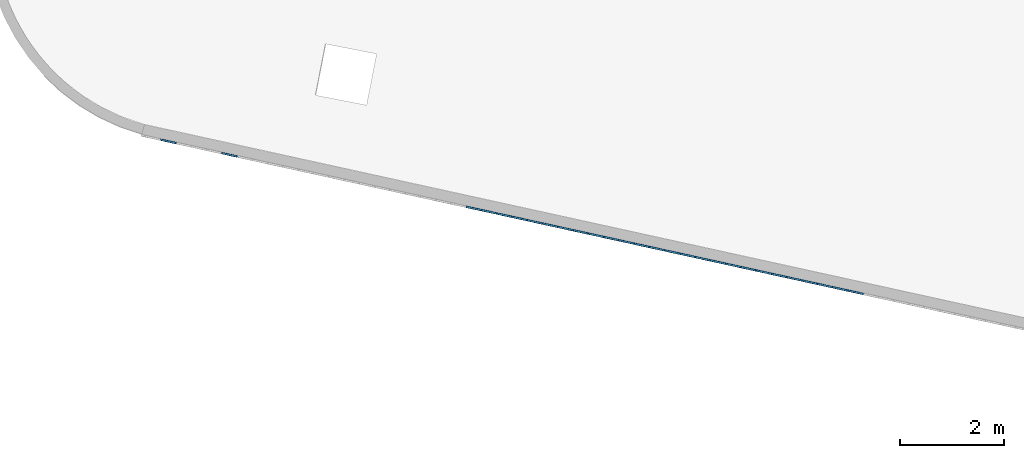
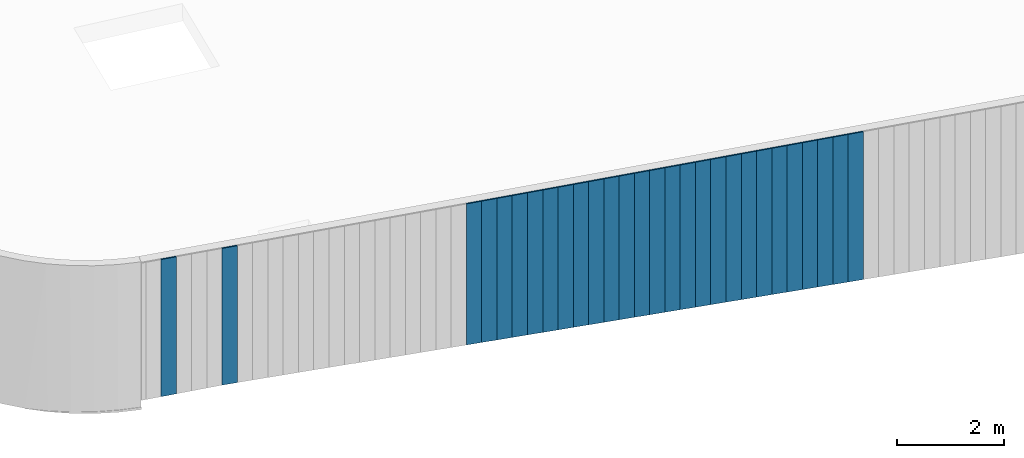
# One storey, part 1 of 18: 28 plates, 1 element without a shape of its own.
"""IFC2X3 building model written with IfcOpenShell, lengths in centimetres."""

from ifc_helpers import new_model, entity, si_unit, converted_unit, derived_unit, direction, frame, origin, place, context, subcontext, project, spatial, polyline, outline, extrude, source, transform, mapped, material, layer, layer_set, layer_usage, type_object, type_shapes, element, aggregate, save


model = new_model("IFC2X3")

# Units and contexts
model_context = context("Model", 3, precision=0.001, world=origin(), true_north=direction((6.12303176911189e-17, 1.0)))
body_context = subcontext(model_context, "Body", "Model", "MODEL_VIEW")
ifc_project = project(units=[si_unit("LENGTHUNIT", "METRE", prefix="CENTI"), si_unit("AREAUNIT", "SQUARE_METRE"), si_unit("VOLUMEUNIT", "CUBIC_METRE"), converted_unit("PLANEANGLEUNIT", "DEGREE", entity("IfcRatioMeasure", 0.0174532925199433), si_unit("PLANEANGLEUNIT", "RADIAN"), dimensions=[0, 0, 0, 0, 0, 0, 0]), si_unit("MASSUNIT", "GRAM", prefix="KILO"), derived_unit("MASSDENSITYUNIT", [(si_unit("MASSUNIT", "GRAM", prefix="KILO"), 1), (si_unit("LENGTHUNIT", "METRE"), -3)]), si_unit("TIMEUNIT", "SECOND"), si_unit("FREQUENCYUNIT", "HERTZ"), si_unit("THERMODYNAMICTEMPERATUREUNIT", "DEGREE_CELSIUS"), derived_unit("THERMALTRANSMITTANCEUNIT", [(si_unit("MASSUNIT", "GRAM", prefix="KILO"), 1), (si_unit("THERMODYNAMICTEMPERATUREUNIT", "KELVIN"), -1), (si_unit("TIMEUNIT", "SECOND"), -3)]), derived_unit("VOLUMETRICFLOWRATEUNIT", [(si_unit("LENGTHUNIT", "METRE"), 3), (si_unit("TIMEUNIT", "SECOND"), -1)]), si_unit("ELECTRICCURRENTUNIT", "AMPERE"), si_unit("ELECTRICVOLTAGEUNIT", "VOLT"), si_unit("POWERUNIT", "WATT"), si_unit("FORCEUNIT", "NEWTON", prefix="KILO"), si_unit("ILLUMINANCEUNIT", "LUX"), si_unit("LUMINOUSFLUXUNIT", "LUMEN"), si_unit("LUMINOUSINTENSITYUNIT", "CANDELA"), derived_unit("USERDEFINED", [(si_unit("MASSUNIT", "GRAM", prefix="KILO"), -1), (si_unit("LENGTHUNIT", "METRE"), -2), (si_unit("TIMEUNIT", "SECOND"), 3), (si_unit("LUMINOUSFLUXUNIT", "LUMEN"), 1)]), derived_unit("LINEARVELOCITYUNIT", [(si_unit("LENGTHUNIT", "METRE"), 1), (si_unit("TIMEUNIT", "SECOND"), -1)]), si_unit("PRESSUREUNIT", "PASCAL"), derived_unit("USERDEFINED", [(si_unit("LENGTHUNIT", "METRE"), -2), (si_unit("MASSUNIT", "GRAM", prefix="KILO"), 1), (si_unit("TIMEUNIT", "SECOND"), -2)])], contexts=[model_context])

# Site, building, storey
site_placement = place(None, origin())
site = spatial("IfcSite", under=ifc_project, at=site_placement, CompositionType="ELEMENT")
building_placement = place(site_placement, origin())
building = spatial("IfcBuilding", under=site, at=building_placement, CompositionType="ELEMENT")
storey_placement = place(building_placement, frame((0.0, 0.0, 1422.0)))
storey = spatial("IfcBuildingStorey", under=building, at=storey_placement, CompositionType="ELEMENT", Elevation=1422.0)

# Curtain wall, plates
curtain_wall_type = type_object("IfcCurtainWallType", PredefinedType="NOTDEFINED")
curtain_wall_placement = place(storey_placement, frame((0.0, 0.0, -1422.0)))
curtain_wall = element("IfcCurtainWall", 1, at=curtain_wall_placement, inside=storey, type_object=curtain_wall_type)
ifc_material = material()
ifc_layer = layer(ifc_material, 3.0)
ifc_layer_set = layer_set([ifc_layer])
ifc_layer_usage_1 = layer_usage(ifc_layer_set, "AXIS3", "POSITIVE", 0.0492125984251968)
plate_type_1 = type_object("IfcPlateType", Name="Panneau plein ST", PredefinedType="CURTAIN_PANEL", material=ifc_layer_set)
shared_shape_1 = source(origin(), body_context, "Body", "SweptSolid", [
    extrude(outline(polyline([(-169.132854368732, -15.0), (168.833289240814, -15.0), (168.833289240814, 15.0), (-168.533724112897, 15.0), (-169.132854368732, -15.0)])), frame((0.0, 0.0, 169.132854368732), z_axis=(0.0, 1.0, 0.0), x_axis=(0.0, 0.0, 1.0)), (0.0, 0.0, 1.0), 3.0),
])
type_shapes(plate_type_1, [shared_shape_1])
plate_1_placement = place(curtain_wall_placement, frame((5430.19102317724, 780.217240085459, 1084.03385639045), z_axis=(0.0, 0.0, 1.0), x_axis=(-0.976731958442773, 0.214463706385357, 0.0)))
plate_1 = element("IfcPlate", 2, at=plate_1_placement, type_object=plate_type_1, material=ifc_layer_usage_1, ObjectType="Panneau plein ST", context=body_context, shape_type="MappedRepresentation", body=[
    mapped(shared_shape_1, transform((0.0, 0.0, 0.0), scale=1.0)),
])
ifc_layer_usage_2 = layer_usage(ifc_layer_set, "AXIS3", "POSITIVE", 0.0492125984251968)
plate_type_2 = type_object("IfcPlateType", Name="Panneau plein ST", PredefinedType="CURTAIN_PANEL", material=ifc_layer_set)
shared_shape_2 = source(origin(), body_context, "Body", "SweptSolid", [
    extrude(outline(polyline([(-168.833289240814, -15.0), (168.533724112896, -15.0), (168.533724112896, 15.0), (-168.234158984978, 15.0), (-168.833289240814, -15.0)])), frame((0.0, 0.0, 168.833289240814), z_axis=(0.0, 1.0, 0.0), x_axis=(0.0, 0.0, 1.0)), (0.0, 0.0, 1.0), 3.0),
])
type_shapes(plate_type_2, [shared_shape_2])
plate_2_placement = place(curtain_wall_placement, frame((5400.88906442396, 786.65115127702, 1084.63298664629), z_axis=(0.0, 0.0, 1.0), x_axis=(-0.976731958442773, 0.214463706385357, 0.0)))
plate_2 = element("IfcPlate", 3, at=plate_2_placement, type_object=plate_type_2, material=ifc_layer_usage_2, ObjectType="Panneau plein ST", context=body_context, shape_type="MappedRepresentation", body=[
    mapped(shared_shape_2, transform((0.0, 0.0, 0.0), scale=1.0)),
])
ifc_layer_usage_3 = layer_usage(ifc_layer_set, "AXIS3", "POSITIVE", 0.0492125984251968)
plate_type_3 = type_object("IfcPlateType", Name="Panneau plein ST", PredefinedType="CURTAIN_PANEL", material=ifc_layer_set)
shared_shape_3 = source(origin(), body_context, "Body", "SweptSolid", [
    extrude(outline(polyline([(-168.533724112896, -15.0), (168.234158984978, -15.0), (168.234158984978, 15.0), (-167.93459385706, 15.0), (-168.533724112896, -15.0)])), frame((0.0, 0.0, 168.533724112896), z_axis=(0.0, 1.0, 0.0), x_axis=(0.0, 0.0, 1.0)), (0.0, 0.0, 1.0), 3.0),
])
type_shapes(plate_type_3, [shared_shape_3])
plate_3_placement = place(curtain_wall_placement, frame((5371.58710567067, 793.085062468581, 1085.23211690213), z_axis=(0.0, 0.0, 1.0), x_axis=(-0.976731958442773, 0.214463706385357, 0.0)))
plate_3 = element("IfcPlate", 4, at=plate_3_placement, type_object=plate_type_3, material=ifc_layer_usage_3, ObjectType="Panneau plein ST", context=body_context, shape_type="MappedRepresentation", body=[
    mapped(shared_shape_3, transform((0.0, 0.0, 0.0), scale=1.0)),
])
ifc_layer_usage_4 = layer_usage(ifc_layer_set, "AXIS3", "POSITIVE", 0.0492125984251968)
plate_type_4 = type_object("IfcPlateType", Name="Panneau plein ST", PredefinedType="CURTAIN_PANEL", material=ifc_layer_set)
shared_shape_4 = source(origin(), body_context, "Body", "SweptSolid", [
    extrude(outline(polyline([(-168.234158984978, -15.0), (167.93459385706, -15.0), (167.93459385706, 15.0), (-167.635028729142, 15.0), (-168.234158984978, -15.0)])), frame((0.0, 0.0, 168.234158984978), z_axis=(0.0, 1.0, 0.0), x_axis=(0.0, 0.0, 1.0)), (0.0, 0.0, 1.0), 3.0),
])
type_shapes(plate_type_4, [shared_shape_4])
plate_4_placement = place(curtain_wall_placement, frame((5342.28514691739, 799.518973660141, 1085.83124715796), z_axis=(0.0, 0.0, 1.0), x_axis=(-0.976731958442773, 0.214463706385357, 0.0)))
plate_4 = element("IfcPlate", 5, at=plate_4_placement, type_object=plate_type_4, material=ifc_layer_usage_4, ObjectType="Panneau plein ST", context=body_context, shape_type="MappedRepresentation", body=[
    mapped(shared_shape_4, transform((0.0, 0.0, 0.0), scale=1.0)),
])
ifc_layer_usage_5 = layer_usage(ifc_layer_set, "AXIS3", "POSITIVE", 0.0492125984251968)
plate_type_5 = type_object("IfcPlateType", Name="Panneau plein ST", PredefinedType="CURTAIN_PANEL", material=ifc_layer_set)
shared_shape_5 = source(origin(), body_context, "Body", "SweptSolid", [
    extrude(outline(polyline([(-167.93459385706, -15.0), (167.635028729142, -15.0), (167.635028729142, 15.0), (-167.335463601224, 15.0), (-167.93459385706, -15.0)])), frame((0.0, 0.0, 167.93459385706), z_axis=(0.0, 1.0, 0.0), x_axis=(0.0, 0.0, 1.0)), (0.0, 0.0, 1.0), 3.0),
])
type_shapes(plate_type_5, [shared_shape_5])
plate_5_placement = place(curtain_wall_placement, frame((5312.98318816411, 805.952884851702, 1086.4303774138), z_axis=(0.0, 0.0, 1.0), x_axis=(-0.976731958442773, 0.214463706385357, 0.0)))
plate_5 = element("IfcPlate", 6, at=plate_5_placement, type_object=plate_type_5, material=ifc_layer_usage_5, ObjectType="Panneau plein ST", context=body_context, shape_type="MappedRepresentation", body=[
    mapped(shared_shape_5, transform((0.0, 0.0, 0.0), scale=1.0)),
])
ifc_layer_usage_6 = layer_usage(ifc_layer_set, "AXIS3", "POSITIVE", 0.0492125984251968)
plate_type_6 = type_object("IfcPlateType", Name="Panneau plein ST", PredefinedType="CURTAIN_PANEL", material=ifc_layer_set)
shared_shape_6 = source(origin(), body_context, "Body", "SweptSolid", [
    extrude(outline(polyline([(-167.635028729142, -15.0), (167.335463601224, -15.0), (167.335463601224, 15.0), (-167.035898473306, 15.0), (-167.635028729142, -15.0)])), frame((0.0, 0.0, 167.635028729142), z_axis=(0.0, 1.0, 0.0), x_axis=(0.0, 0.0, 1.0)), (0.0, 0.0, 1.0), 3.0),
])
type_shapes(plate_type_6, [shared_shape_6])
plate_6_placement = place(curtain_wall_placement, frame((5283.68122941082, 812.386796043263, 1087.02950766963), z_axis=(0.0, 0.0, 1.0), x_axis=(-0.976731958442773, 0.214463706385357, 0.0)))
plate_6 = element("IfcPlate", 7, at=plate_6_placement, type_object=plate_type_6, material=ifc_layer_usage_6, ObjectType="Panneau plein ST", context=body_context, shape_type="MappedRepresentation", body=[
    mapped(shared_shape_6, transform((0.0, 0.0, 0.0), scale=1.0)),
])
ifc_layer_usage_7 = layer_usage(ifc_layer_set, "AXIS3", "POSITIVE", 0.0492125984251968)
plate_type_7 = type_object("IfcPlateType", Name="Panneau plein ST", PredefinedType="CURTAIN_PANEL", material=ifc_layer_set)
shared_shape_7 = source(origin(), body_context, "Body", "SweptSolid", [
    extrude(outline(polyline([(-167.335463601224, -15.0), (167.035898473306, -15.0), (167.035898473306, 15.0), (-166.736333345388, 15.0), (-167.335463601224, -15.0)])), frame((0.0, 0.0, 167.335463601224), z_axis=(0.0, 1.0, 0.0), x_axis=(0.0, 0.0, 1.0)), (0.0, 0.0, 1.0), 3.0),
])
type_shapes(plate_type_7, [shared_shape_7])
plate_7_placement = place(curtain_wall_placement, frame((5254.37927065754, 818.820707234823, 1087.62863792547), z_axis=(0.0, 0.0, 1.0), x_axis=(-0.976731958442773, 0.214463706385357, 0.0)))
plate_7 = element("IfcPlate", 8, at=plate_7_placement, type_object=plate_type_7, material=ifc_layer_usage_7, ObjectType="Panneau plein ST", context=body_context, shape_type="MappedRepresentation", body=[
    mapped(shared_shape_7, transform((0.0, 0.0, 0.0), scale=1.0)),
])
ifc_layer_usage_8 = layer_usage(ifc_layer_set, "AXIS3", "POSITIVE", 0.0492125984251968)
plate_type_8 = type_object("IfcPlateType", Name="Panneau plein ST", PredefinedType="CURTAIN_PANEL", material=ifc_layer_set)
shared_shape_8 = source(origin(), body_context, "Body", "SweptSolid", [
    extrude(outline(polyline([(-167.035898473306, -15.0), (166.736333345388, -15.0), (166.736333345388, 15.0), (-166.43676821747, 15.0), (-167.035898473306, -15.0)])), frame((0.0, 0.0, 167.035898473306), z_axis=(0.0, 1.0, 0.0), x_axis=(0.0, 0.0, 1.0)), (0.0, 0.0, 1.0), 3.0),
])
type_shapes(plate_type_8, [shared_shape_8])
plate_8_placement = place(curtain_wall_placement, frame((5225.07731190426, 825.254618426384, 1088.22776818131), z_axis=(0.0, 0.0, 1.0), x_axis=(-0.976731958442773, 0.214463706385357, 0.0)))
plate_8 = element("IfcPlate", 9, at=plate_8_placement, type_object=plate_type_8, material=ifc_layer_usage_8, ObjectType="Panneau plein ST", context=body_context, shape_type="MappedRepresentation", body=[
    mapped(shared_shape_8, transform((0.0, 0.0, 0.0), scale=1.0)),
])
ifc_layer_usage_9 = layer_usage(ifc_layer_set, "AXIS3", "POSITIVE", 0.0492125984251968)
plate_type_9 = type_object("IfcPlateType", Name="Panneau plein ST", PredefinedType="CURTAIN_PANEL", material=ifc_layer_set)
shared_shape_9 = source(origin(), body_context, "Body", "SweptSolid", [
    extrude(outline(polyline([(-166.736333345388, -15.0), (166.43676821747, -15.0), (166.43676821747, 15.0), (-166.137203089552, 15.0), (-166.736333345388, -15.0)])), frame((0.0, 0.0, 166.736333345388), z_axis=(0.0, 1.0, 0.0), x_axis=(0.0, 0.0, 1.0)), (0.0, 0.0, 1.0), 3.0),
])
type_shapes(plate_type_9, [shared_shape_9])
plate_9_placement = place(curtain_wall_placement, frame((5195.77535315098, 831.688529617945, 1088.82689843714), z_axis=(0.0, 0.0, 1.0), x_axis=(-0.976731958442773, 0.214463706385357, 0.0)))
plate_9 = element("IfcPlate", 10, at=plate_9_placement, type_object=plate_type_9, material=ifc_layer_usage_9, ObjectType="Panneau plein ST", context=body_context, shape_type="MappedRepresentation", body=[
    mapped(shared_shape_9, transform((0.0, 0.0, 0.0), scale=1.0)),
])
ifc_layer_usage_10 = layer_usage(ifc_layer_set, "AXIS3", "POSITIVE", 0.0492125984251968)
plate_type_10 = type_object("IfcPlateType", Name="Panneau plein ST", PredefinedType="CURTAIN_PANEL", material=ifc_layer_set)
shared_shape_10 = source(origin(), body_context, "Body", "SweptSolid", [
    extrude(outline(polyline([(-166.43676821747, -15.0), (166.137203089552, -15.0), (166.137203089552, 15.0), (-165.837637961634, 15.0), (-166.43676821747, -15.0)])), frame((0.0, 0.0, 166.43676821747), z_axis=(0.0, 1.0, 0.0), x_axis=(0.0, 0.0, 1.0)), (0.0, 0.0, 1.0), 3.0),
])
type_shapes(plate_type_10, [shared_shape_10])
plate_10_placement = place(curtain_wall_placement, frame((5166.47339439769, 838.122440809506, 1089.42602869298), z_axis=(0.0, 0.0, 1.0), x_axis=(-0.976731958442773, 0.214463706385357, 0.0)))
plate_10 = element("IfcPlate", 11, at=plate_10_placement, type_object=plate_type_10, material=ifc_layer_usage_10, ObjectType="Panneau plein ST", context=body_context, shape_type="MappedRepresentation", body=[
    mapped(shared_shape_10, transform((0.0, 0.0, 0.0), scale=1.0)),
])
ifc_layer_usage_11 = layer_usage(ifc_layer_set, "AXIS3", "POSITIVE", 0.0492125984251968)
plate_type_11 = type_object("IfcPlateType", Name="Panneau plein ST", PredefinedType="CURTAIN_PANEL", material=ifc_layer_set)
shared_shape_11 = source(origin(), body_context, "Body", "SweptSolid", [
    extrude(outline(polyline([(-166.137203089552, -15.0), (165.837637961634, -15.0), (165.837637961634, 15.0), (-165.538072833716, 15.0), (-166.137203089552, -15.0)])), frame((0.0, 0.0, 166.137203089552), z_axis=(0.0, 1.0, 0.0), x_axis=(0.0, 0.0, 1.0)), (0.0, 0.0, 1.0), 3.0),
])
type_shapes(plate_type_11, [shared_shape_11])
plate_11_placement = place(curtain_wall_placement, frame((5137.17143564441, 844.556352001067, 1090.02515894881), z_axis=(0.0, 0.0, 1.0), x_axis=(-0.976731958442773, 0.214463706385357, 0.0)))
plate_11 = element("IfcPlate", 12, at=plate_11_placement, type_object=plate_type_11, material=ifc_layer_usage_11, ObjectType="Panneau plein ST", context=body_context, shape_type="MappedRepresentation", body=[
    mapped(shared_shape_11, transform((0.0, 0.0, 0.0), scale=1.0)),
])
ifc_layer_usage_12 = layer_usage(ifc_layer_set, "AXIS3", "POSITIVE", 0.0492125984251968)
plate_type_12 = type_object("IfcPlateType", Name="Panneau plein ST", PredefinedType="CURTAIN_PANEL", material=ifc_layer_set)
shared_shape_12 = source(origin(), body_context, "Body", "SweptSolid", [
    extrude(outline(polyline([(-165.837637961634, -15.0), (165.538072833716, -15.0), (165.538072833716, 15.0), (-165.238507705798, 15.0), (-165.837637961634, -15.0)])), frame((0.0, 0.0, 165.837637961634), z_axis=(0.0, 1.0, 0.0), x_axis=(0.0, 0.0, 1.0)), (0.0, 0.0, 1.0), 3.0),
])
type_shapes(plate_type_12, [shared_shape_12])
plate_12_placement = place(curtain_wall_placement, frame((5107.86947689113, 850.990263192627, 1090.62428920465), z_axis=(0.0, 0.0, 1.0), x_axis=(-0.976731958442773, 0.214463706385357, 0.0)))
plate_12 = element("IfcPlate", 13, at=plate_12_placement, type_object=plate_type_12, material=ifc_layer_usage_12, ObjectType="Panneau plein ST", context=body_context, shape_type="MappedRepresentation", body=[
    mapped(shared_shape_12, transform((0.0, 0.0, 0.0), scale=1.0)),
])
ifc_layer_usage_13 = layer_usage(ifc_layer_set, "AXIS3", "POSITIVE", 0.0492125984251968)
plate_type_13 = type_object("IfcPlateType", Name="Panneau plein ST", PredefinedType="CURTAIN_PANEL", material=ifc_layer_set)
shared_shape_13 = source(origin(), body_context, "Body", "SweptSolid", [
    extrude(outline(polyline([(-165.538072833716, -15.0), (165.238507705798, -15.0), (165.238507705798, 15.0), (-164.93894257788, 15.0), (-165.538072833716, -15.0)])), frame((0.0, 0.0, 165.538072833716), z_axis=(0.0, 1.0, 0.0), x_axis=(0.0, 0.0, 1.0)), (0.0, 0.0, 1.0), 3.0),
])
type_shapes(plate_type_13, [shared_shape_13])
plate_13_placement = place(curtain_wall_placement, frame((5078.56751813784, 857.424174384188, 1091.22341946049), z_axis=(0.0, 0.0, 1.0), x_axis=(-0.976731958442773, 0.214463706385357, 0.0)))
plate_13 = element("IfcPlate", 14, at=plate_13_placement, type_object=plate_type_13, material=ifc_layer_usage_13, ObjectType="Panneau plein ST", context=body_context, shape_type="MappedRepresentation", body=[
    mapped(shared_shape_13, transform((0.0, 0.0, 0.0), scale=1.0)),
])
ifc_layer_usage_14 = layer_usage(ifc_layer_set, "AXIS3", "POSITIVE", 0.0492125984251968)
plate_type_14 = type_object("IfcPlateType", Name="Panneau plein ST", PredefinedType="CURTAIN_PANEL", material=ifc_layer_set)
shared_shape_14 = source(origin(), body_context, "Body", "SweptSolid", [
    extrude(outline(polyline([(-165.238507705798, -15.0), (164.93894257788, -15.0), (164.93894257788, 15.0), (-164.639377449962, 15.0), (-165.238507705798, -15.0)])), frame((0.0, 0.0, 165.238507705798), z_axis=(0.0, 1.0, 0.0), x_axis=(0.0, 0.0, 1.0)), (0.0, 0.0, 1.0), 3.0),
])
type_shapes(plate_type_14, [shared_shape_14])
plate_14_placement = place(curtain_wall_placement, frame((5049.26555938456, 863.858085575749, 1091.82254971632), z_axis=(0.0, 0.0, 1.0), x_axis=(-0.976731958442773, 0.214463706385357, 0.0)))
plate_14 = element("IfcPlate", 15, at=plate_14_placement, type_object=plate_type_14, material=ifc_layer_usage_14, ObjectType="Panneau plein ST", context=body_context, shape_type="MappedRepresentation", body=[
    mapped(shared_shape_14, transform((0.0, 0.0, 0.0), scale=1.0)),
])
ifc_layer_usage_15 = layer_usage(ifc_layer_set, "AXIS3", "POSITIVE", 0.0492125984251968)
plate_type_15 = type_object("IfcPlateType", Name="Panneau plein ST", PredefinedType="CURTAIN_PANEL", material=ifc_layer_set)
shared_shape_15 = source(origin(), body_context, "Body", "SweptSolid", [
    extrude(outline(polyline([(-164.93894257788, -15.0), (164.639377449962, -15.0), (164.639377449962, 15.0), (-164.339812322044, 15.0), (-164.93894257788, -15.0)])), frame((0.0, 0.0, 164.93894257788), z_axis=(0.0, 1.0, 0.0), x_axis=(0.0, 0.0, 1.0)), (0.0, 0.0, 1.0), 3.0),
])
type_shapes(plate_type_15, [shared_shape_15])
plate_15_placement = place(curtain_wall_placement, frame((5019.96360063128, 870.29199676731, 1092.42167997216), z_axis=(0.0, 0.0, 1.0), x_axis=(-0.976731958442773, 0.214463706385357, 0.0)))
plate_15 = element("IfcPlate", 16, at=plate_15_placement, type_object=plate_type_15, material=ifc_layer_usage_15, ObjectType="Panneau plein ST", context=body_context, shape_type="MappedRepresentation", body=[
    mapped(shared_shape_15, transform((0.0, 0.0, 0.0), scale=1.0)),
])
ifc_layer_usage_16 = layer_usage(ifc_layer_set, "AXIS3", "POSITIVE", 0.0492125984251968)
plate_type_16 = type_object("IfcPlateType", Name="Panneau plein ST", PredefinedType="CURTAIN_PANEL", material=ifc_layer_set)
shared_shape_16 = source(origin(), body_context, "Body", "SweptSolid", [
    extrude(outline(polyline([(-164.639377449962, -15.0), (164.339812322044, -15.0), (164.339812322044, 15.0), (-164.040247194126, 15.0), (-164.639377449962, -15.0)])), frame((0.0, 0.0, 164.639377449962), z_axis=(0.0, 1.0, 0.0), x_axis=(0.0, 0.0, 1.0)), (0.0, 0.0, 1.0), 3.0),
])
type_shapes(plate_type_16, [shared_shape_16])
plate_16_placement = place(curtain_wall_placement, frame((4990.66164187799, 876.72590795887, 1093.02081022799), z_axis=(0.0, 0.0, 1.0), x_axis=(-0.976731958442773, 0.214463706385357, 0.0)))
plate_16 = element("IfcPlate", 17, at=plate_16_placement, type_object=plate_type_16, material=ifc_layer_usage_16, ObjectType="Panneau plein ST", context=body_context, shape_type="MappedRepresentation", body=[
    mapped(shared_shape_16, transform((0.0, 0.0, 0.0), scale=1.0)),
])
ifc_layer_usage_17 = layer_usage(ifc_layer_set, "AXIS3", "POSITIVE", 0.0492125984251968)
plate_type_17 = type_object("IfcPlateType", Name="Panneau plein ST", PredefinedType="CURTAIN_PANEL", material=ifc_layer_set)
shared_shape_17 = source(origin(), body_context, "Body", "SweptSolid", [
    extrude(outline(polyline([(-164.339812322044, -15.0), (164.040247194126, -15.0), (164.040247194126, 15.0), (-163.740682066208, 15.0), (-164.339812322044, -15.0)])), frame((0.0, 0.0, 164.339812322044), z_axis=(0.0, 1.0, 0.0), x_axis=(0.0, 0.0, 1.0)), (0.0, 0.0, 1.0), 3.0),
])
type_shapes(plate_type_17, [shared_shape_17])
plate_17_placement = place(curtain_wall_placement, frame((4961.35968312471, 883.159819150431, 1093.61994048383), z_axis=(0.0, 0.0, 1.0), x_axis=(-0.976731958442773, 0.214463706385357, 0.0)))
plate_17 = element("IfcPlate", 18, at=plate_17_placement, type_object=plate_type_17, material=ifc_layer_usage_17, ObjectType="Panneau plein ST", context=body_context, shape_type="MappedRepresentation", body=[
    mapped(shared_shape_17, transform((0.0, 0.0, 0.0), scale=1.0)),
])
ifc_layer_usage_18 = layer_usage(ifc_layer_set, "AXIS3", "POSITIVE", 0.0492125984251968)
plate_type_18 = type_object("IfcPlateType", Name="Panneau plein ST", PredefinedType="CURTAIN_PANEL", material=ifc_layer_set)
shared_shape_18 = source(origin(), body_context, "Body", "SweptSolid", [
    extrude(outline(polyline([(-164.040247194126, -15.0), (163.740682066208, -15.0), (163.740682066208, 15.0), (-163.44111693829, 15.0), (-164.040247194126, -15.0)])), frame((0.0, 0.0, 164.040247194126), z_axis=(0.0, 1.0, 0.0), x_axis=(0.0, 0.0, 1.0)), (0.0, 0.0, 1.0), 3.0),
])
type_shapes(plate_type_18, [shared_shape_18])
plate_18_placement = place(curtain_wall_placement, frame((4932.05772437143, 889.593730341992, 1094.21907073967), z_axis=(0.0, 0.0, 1.0), x_axis=(-0.976731958442773, 0.214463706385357, 0.0)))
plate_18 = element("IfcPlate", 19, at=plate_18_placement, type_object=plate_type_18, material=ifc_layer_usage_18, ObjectType="Panneau plein ST", context=body_context, shape_type="MappedRepresentation", body=[
    mapped(shared_shape_18, transform((0.0, 0.0, 0.0), scale=1.0)),
])
ifc_layer_usage_19 = layer_usage(ifc_layer_set, "AXIS3", "POSITIVE", 0.0492125984251968)
plate_type_19 = type_object("IfcPlateType", Name="Panneau plein ST", PredefinedType="CURTAIN_PANEL", material=ifc_layer_set)
shared_shape_19 = source(origin(), body_context, "Body", "SweptSolid", [
    extrude(outline(polyline([(-163.740682066208, -15.0), (163.44111693829, -15.0), (163.44111693829, 15.0), (-163.141551810372, 15.0), (-163.740682066208, -15.0)])), frame((0.0, 0.0, 163.740682066208), z_axis=(0.0, 1.0, 0.0), x_axis=(0.0, 0.0, 1.0)), (0.0, 0.0, 1.0), 3.0),
])
type_shapes(plate_type_19, [shared_shape_19])
plate_19_placement = place(curtain_wall_placement, frame((4902.75576561814, 896.027641533552, 1094.8182009955), z_axis=(0.0, 0.0, 1.0), x_axis=(-0.976731958442773, 0.214463706385357, 0.0)))
plate_19 = element("IfcPlate", 20, at=plate_19_placement, type_object=plate_type_19, material=ifc_layer_usage_19, ObjectType="Panneau plein ST", context=body_context, shape_type="MappedRepresentation", body=[
    mapped(shared_shape_19, transform((0.0, 0.0, 0.0), scale=1.0)),
])
ifc_layer_usage_20 = layer_usage(ifc_layer_set, "AXIS3", "POSITIVE", 0.0492125984251968)
plate_type_20 = type_object("IfcPlateType", Name="Panneau plein ST", PredefinedType="CURTAIN_PANEL", material=ifc_layer_set)
shared_shape_20 = source(origin(), body_context, "Body", "SweptSolid", [
    extrude(outline(polyline([(-163.44111693829, -15.0), (163.141551810372, -15.0), (163.141551810372, 15.0), (-162.841986682454, 15.0), (-163.44111693829, -15.0)])), frame((0.0, 0.0, 163.44111693829), z_axis=(0.0, 1.0, 0.0), x_axis=(0.0, 0.0, 1.0)), (0.0, 0.0, 1.0), 3.0),
])
type_shapes(plate_type_20, [shared_shape_20])
plate_20_placement = place(curtain_wall_placement, frame((4873.45380686486, 902.461552725113, 1095.41733125134), z_axis=(0.0, 0.0, 1.0), x_axis=(-0.976731958442773, 0.214463706385357, 0.0)))
plate_20 = element("IfcPlate", 21, at=plate_20_placement, type_object=plate_type_20, material=ifc_layer_usage_20, ObjectType="Panneau plein ST", context=body_context, shape_type="MappedRepresentation", body=[
    mapped(shared_shape_20, transform((0.0, 0.0, 0.0), scale=1.0)),
])
ifc_layer_usage_21 = layer_usage(ifc_layer_set, "AXIS3", "POSITIVE", 0.0492125984251968)
plate_type_21 = type_object("IfcPlateType", Name="Panneau plein ST", PredefinedType="CURTAIN_PANEL", material=ifc_layer_set)
shared_shape_21 = source(origin(), body_context, "Body", "SweptSolid", [
    extrude(outline(polyline([(-163.141551810372, -15.0), (162.841986682454, -15.0), (162.841986682454, 15.0), (-162.542421554536, 15.0), (-163.141551810372, -15.0)])), frame((0.0, 0.0, 163.141551810372), z_axis=(0.0, 1.0, 0.0), x_axis=(0.0, 0.0, 1.0)), (0.0, 0.0, 1.0), 3.0),
])
type_shapes(plate_type_21, [shared_shape_21])
plate_21_placement = place(curtain_wall_placement, frame((4844.15184811158, 908.895463916674, 1096.01646150717), z_axis=(0.0, 0.0, 1.0), x_axis=(-0.976731958442773, 0.214463706385357, 0.0)))
plate_21 = element("IfcPlate", 22, at=plate_21_placement, type_object=plate_type_21, material=ifc_layer_usage_21, ObjectType="Panneau plein ST", context=body_context, shape_type="MappedRepresentation", body=[
    mapped(shared_shape_21, transform((0.0, 0.0, 0.0), scale=1.0)),
])
ifc_layer_usage_22 = layer_usage(ifc_layer_set, "AXIS3", "POSITIVE", 0.0492125984251968)
plate_type_22 = type_object("IfcPlateType", Name="Panneau plein ST", PredefinedType="CURTAIN_PANEL", material=ifc_layer_set)
shared_shape_22 = source(origin(), body_context, "Body", "SweptSolid", [
    extrude(outline(polyline([(-162.841986682454, -15.0), (162.542421554536, -15.0), (162.542421554536, 15.0), (-162.242856426618, 15.0), (-162.841986682454, -15.0)])), frame((0.0, 0.0, 162.841986682454), z_axis=(0.0, 1.0, 0.0), x_axis=(0.0, 0.0, 1.0)), (0.0, 0.0, 1.0), 3.0),
])
type_shapes(plate_type_22, [shared_shape_22])
plate_22_placement = place(curtain_wall_placement, frame((4814.84988935829, 915.329375108234, 1096.61559176301), z_axis=(0.0, 0.0, 1.0), x_axis=(-0.976731958442773, 0.214463706385357, 0.0)))
plate_22 = element("IfcPlate", 23, at=plate_22_placement, type_object=plate_type_22, material=ifc_layer_usage_22, ObjectType="Panneau plein ST", context=body_context, shape_type="MappedRepresentation", body=[
    mapped(shared_shape_22, transform((0.0, 0.0, 0.0), scale=1.0)),
])
ifc_layer_usage_23 = layer_usage(ifc_layer_set, "AXIS3", "POSITIVE", 0.0492125984251968)
plate_type_23 = type_object("IfcPlateType", Name="Panneau plein ST", PredefinedType="CURTAIN_PANEL", material=ifc_layer_set)
shared_shape_23 = source(origin(), body_context, "Body", "SweptSolid", [
    extrude(outline(polyline([(-162.542421554536, -15.0), (162.242856426618, -15.0), (162.242856426618, 15.0), (-161.9432912987, 15.0), (-162.542421554536, -15.0)])), frame((0.0, 0.0, 162.542421554536), z_axis=(0.0, 1.0, 0.0), x_axis=(0.0, 0.0, 1.0)), (0.0, 0.0, 1.0), 3.0),
])
type_shapes(plate_type_23, [shared_shape_23])
plate_23_placement = place(curtain_wall_placement, frame((4785.54793060501, 921.763286299795, 1097.21472201885), z_axis=(0.0, 0.0, 1.0), x_axis=(-0.976731958442773, 0.214463706385357, 0.0)))
plate_23 = element("IfcPlate", 24, at=plate_23_placement, type_object=plate_type_23, material=ifc_layer_usage_23, ObjectType="Panneau plein ST", context=body_context, shape_type="MappedRepresentation", body=[
    mapped(shared_shape_23, transform((0.0, 0.0, 0.0), scale=1.0)),
])
ifc_layer_usage_24 = layer_usage(ifc_layer_set, "AXIS3", "POSITIVE", 0.0492125984251968)
plate_type_24 = type_object("IfcPlateType", Name="Panneau plein ST", PredefinedType="CURTAIN_PANEL", material=ifc_layer_set)
shared_shape_24 = source(origin(), body_context, "Body", "SweptSolid", [
    extrude(outline(polyline([(-162.242856426618, -15.0), (161.9432912987, -15.0), (161.9432912987, 15.0), (-161.643726170782, 15.0), (-162.242856426618, -15.0)])), frame((0.0, 0.0, 162.242856426618), z_axis=(0.0, 1.0, 0.0), x_axis=(0.0, 0.0, 1.0)), (0.0, 0.0, 1.0), 3.0),
])
type_shapes(plate_type_24, [shared_shape_24])
plate_24_placement = place(curtain_wall_placement, frame((4756.24597185172, 928.197197491356, 1097.81385227468), z_axis=(0.0, 0.0, 1.0), x_axis=(-0.976731958442773, 0.214463706385357, 0.0)))
plate_24 = element("IfcPlate", 25, at=plate_24_placement, type_object=plate_type_24, material=ifc_layer_usage_24, ObjectType="Panneau plein ST", context=body_context, shape_type="MappedRepresentation", body=[
    mapped(shared_shape_24, transform((0.0, 0.0, 0.0), scale=1.0)),
])
ifc_layer_usage_25 = layer_usage(ifc_layer_set, "AXIS3", "POSITIVE", 0.0492125984251968)
plate_type_25 = type_object("IfcPlateType", Name="Panneau plein ST", PredefinedType="CURTAIN_PANEL", material=ifc_layer_set)
shared_shape_25 = source(origin(), body_context, "Body", "SweptSolid", [
    extrude(outline(polyline([(-161.9432912987, -15.0), (161.643726170782, -15.0), (161.643726170782, 15.0), (-161.344161042864, 15.0), (-161.9432912987, -15.0)])), frame((0.0, 0.0, 161.9432912987), z_axis=(0.0, 1.0, 0.0), x_axis=(0.0, 0.0, 1.0)), (0.0, 0.0, 1.0), 3.0),
])
type_shapes(plate_type_25, [shared_shape_25])
plate_25_placement = place(curtain_wall_placement, frame((4726.94401309844, 934.631108682917, 1098.41298253052), z_axis=(0.0, 0.0, 1.0), x_axis=(-0.976731958442773, 0.214463706385357, 0.0)))
plate_25 = element("IfcPlate", 26, at=plate_25_placement, type_object=plate_type_25, material=ifc_layer_usage_25, ObjectType="Panneau plein ST", context=body_context, shape_type="MappedRepresentation", body=[
    mapped(shared_shape_25, transform((0.0, 0.0, 0.0), scale=1.0)),
])
ifc_layer_usage_26 = layer_usage(ifc_layer_set, "AXIS3", "POSITIVE", 0.0492125984251968)
plate_type_26 = type_object("IfcPlateType", Name="Panneau plein ST", PredefinedType="CURTAIN_PANEL", material=ifc_layer_set)
shared_shape_26 = source(origin(), body_context, "Body", "SweptSolid", [
    extrude(outline(polyline([(-161.643726170782, -15.0), (161.344161042864, -15.0), (161.344161042864, 15.0), (-161.044595914946, 15.0), (-161.643726170782, -15.0)])), frame((0.0, 0.0, 161.643726170782), z_axis=(0.0, 1.0, 0.0), x_axis=(0.0, 0.0, 1.0)), (0.0, 0.0, 1.0), 3.0),
])
type_shapes(plate_type_26, [shared_shape_26])
plate_26_placement = place(curtain_wall_placement, frame((4697.64205434516, 941.065019874478, 1099.01211278635), z_axis=(0.0, 0.0, 1.0), x_axis=(-0.976731958442773, 0.214463706385357, 0.0)))
plate_26 = element("IfcPlate", 27, at=plate_26_placement, type_object=plate_type_26, material=ifc_layer_usage_26, ObjectType="Panneau plein ST", context=body_context, shape_type="MappedRepresentation", body=[
    mapped(shared_shape_26, transform((0.0, 0.0, 0.0), scale=1.0)),
])
ifc_layer_usage_27 = layer_usage(ifc_layer_set, "AXIS3", "POSITIVE", 0.0492125984251968)
plate_type_27 = type_object("IfcPlateType", Name="Panneau plein ST", PredefinedType="CURTAIN_PANEL", material=ifc_layer_set)
shared_shape_27 = source(origin(), body_context, "Body", "SweptSolid", [
    extrude(outline(polyline([(-125.362651672811, -16.8701617948923), (187.583722293876, -16.8701617948923), (187.583722293876, 13.1298382051086), (-124.925953519379, 13.1298382051081), (-124.878839395563, 7.48064717956783), (-125.362651672811, -16.8701617948923)])), frame((1.87016179489206, 0.0, 125.362651672811), z_axis=(0.0, 1.0, 0.0), x_axis=(0.0, 0.0, 1.0)), (0.0, 0.0, 1.0), 3.0),
])
type_shapes(plate_type_27, [shared_shape_27])
plate_27_placement = place(curtain_wall_placement, frame((4228.81071429263, 1044.00759893945, 1109.05362603331), z_axis=(0.0, 0.0, 1.0), x_axis=(-0.976731958442773, 0.214463706385357, 0.0)))
plate_27 = element("IfcPlate", 28, at=plate_27_placement, type_object=plate_type_27, material=ifc_layer_usage_27, ObjectType="Panneau plein ST", context=body_context, shape_type="MappedRepresentation", body=[
    mapped(shared_shape_27, transform((0.0, 0.0, 0.0), scale=1.0)),
])
ifc_layer_usage_28 = layer_usage(ifc_layer_set, "AXIS3", "POSITIVE", 0.0492125984251968)
plate_type_28 = type_object("IfcPlateType", Name="Panneau plein ST", PredefinedType="CURTAIN_PANEL", material=ifc_layer_set)
shared_shape_28 = source(origin(), body_context, "Body", "SweptSolid", [
    extrude(outline(polyline([(-156.567587048072, -15.0), (156.69268670465, -15.0), (156.69268670465, 15.0), (-156.817786361228, 15.0), (-156.567587048072, -15.0)])), frame((0.0, 0.0, 156.817786361228), z_axis=(0.0, 1.0, 0.0), x_axis=(0.0, 0.0, 1.0)), (0.0, 0.0, 1.0), 3.0),
])
type_shapes(plate_type_28, [shared_shape_28])
plate_28_placement = place(curtain_wall_placement, frame((4111.60287927949, 1069.74324370569, 1108.48952693412), z_axis=(0.0, 0.0, 1.0), x_axis=(-0.976731958442773, 0.214463706385357, 0.0)))
plate_28 = element("IfcPlate", 29, at=plate_28_placement, type_object=plate_type_28, material=ifc_layer_usage_28, ObjectType="Panneau plein ST", context=body_context, shape_type="MappedRepresentation", body=[
    mapped(shared_shape_28, transform((0.0, 0.0, 0.0), scale=1.0)),
])
aggregate(curtain_wall, [plate_1, plate_2, plate_3, plate_4, plate_5, plate_6, plate_7, plate_8, plate_9, plate_10, plate_11, plate_12, plate_13, plate_14, plate_15, plate_16, plate_17, plate_18, plate_19, plate_20, plate_21, plate_22, plate_23, plate_24, plate_25, plate_26, plate_27, plate_28])

save(model, "model.ifc")
